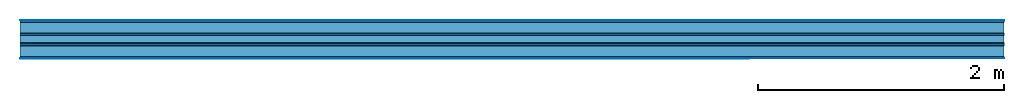
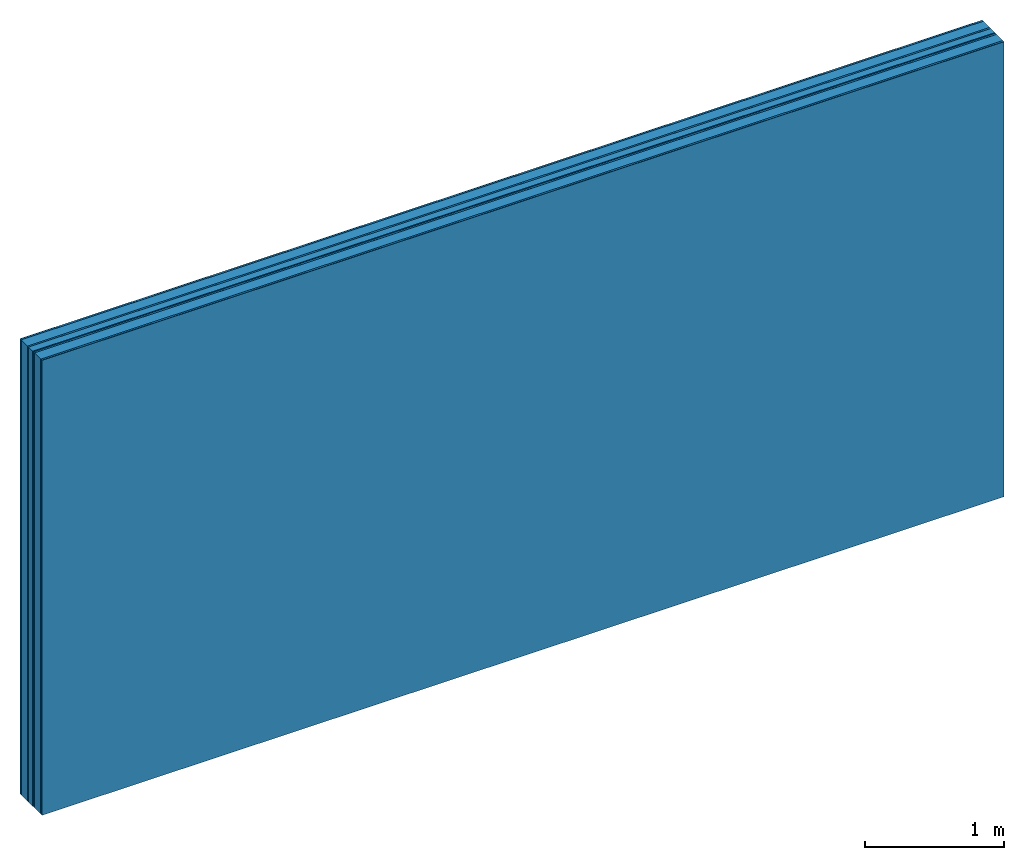
# One storey: 8 plates, 2 members, 1 element without a shape of its own.
"""IFC4 building model written with IfcOpenShell, lengths in metres."""

import ifcopenshell
import ifcopenshell.guid

model = None  # the IFC model being written
_history = None  # IfcOwnerHistory: only IFC2X3 demands one
_inside = {}  # id of a spatial element -> (the spatial element, [elements in it])
_under = {}  # id of a project, library or spatial element -> (it, [spatial elements below it])
_declared = {}  # id of a project -> (the project, [libraries it declares])
_typed = {}  # id of a type object -> (the type object, [elements of that type])
_made_of = {}  # id of a material, layer set ... -> (it, [elements and type objects made of it])


def new_model(schema):
    """Start an empty IFC model of exactly this schema.

    Asked for "IFC4X3", IfcOpenShell would pick the latest addendum, in which some entities
    have other attributes; the version numbers below select the first issue.
    IFC2X3 requires an IfcOwnerHistory on every rooted entity: one is made here for all.
    """
    global model, _history
    if schema == "IFC4X3":
        model = ifcopenshell.file(schema_version=(4, 3, 0, 0))
    else:
        model = ifcopenshell.file(schema=schema)
    _inside.clear()
    _under.clear()
    _declared.clear()
    _typed.clear()
    _made_of.clear()
    _history = None
    if model.schema == "IFC2X3":
        org = make("IfcOrganization", Name="unknown")
        user = make(
            "IfcPersonAndOrganization",
            ThePerson=make("IfcPerson", FamilyName="unknown"),
            TheOrganization=org,
        )
        app = make(
            "IfcApplication",
            ApplicationDeveloper=org,
            Version="unknown",
            ApplicationFullName="unknown",
            ApplicationIdentifier="unknown",
        )
        _history = make(
            "IfcOwnerHistory",
            OwningUser=user,
            OwningApplication=app,
            ChangeAction="ADDED",
            CreationDate=0,
        )
    return model


def make(cls, **values):
    """One entity of the class cls with the attributes given. An attribute that is None is left unset."""
    return model.create_entity(
        cls, **{name: value for name, value in values.items() if value is not None}
    )


def rooted(cls, **values):
    """An entity with a GlobalId (a new one), such as an element, a storey or a relation."""
    return make(cls, GlobalId=ifcopenshell.guid.new(), OwnerHistory=_history, **values)


def si_unit(unit_type, name, prefix=None):
    """IfcSIUnit, for example si_unit("LENGTHUNIT", "METRE", prefix="MILLI")."""
    return make("IfcSIUnit", UnitType=unit_type, Prefix=prefix, Name=name)


def derived_unit(unit_type, elements):
    """IfcDerivedUnit: a product of units, each with its exponent."""
    return make(
        "IfcDerivedUnit",
        Elements=[
            make("IfcDerivedUnitElement", Unit=unit, Exponent=power)
            for unit, power in elements
        ],
        UnitType=unit_type,
    )


def assignment(units):
    """IfcUnitAssignment: the units of a project."""
    return None if units is None else make("IfcUnitAssignment", Units=units)


def point(xyz):
    """IfcCartesianPoint."""
    return None if xyz is None else make("IfcCartesianPoint", Coordinates=xyz)


def direction(xyz):
    """IfcDirection."""
    return None if xyz is None else make("IfcDirection", DirectionRatios=xyz)


def frame(location, z_axis=None, x_axis=None):
    """IfcAxis2Placement3D, a coordinate frame: its origin and axes. An axis left out is left unset."""
    return make(
        "IfcAxis2Placement3D",
        Location=point(location),
        Axis=direction(z_axis),
        RefDirection=direction(x_axis),
    )


def frame_2d(location, x_axis=None):
    """IfcAxis2Placement2D, a coordinate frame in the plane: its origin and x axis."""
    return make(
        "IfcAxis2Placement2D", Location=point(location), RefDirection=direction(x_axis)
    )


def origin():
    """The frame at (0, 0, 0) with its axes left unset."""
    return frame((0.0, 0.0, 0.0))


def origin_with_axes():
    """The frame at (0, 0, 0) with the z axis (0, 0, 1) and the x axis (1, 0, 0) written out."""
    return frame((0.0, 0.0, 0.0), z_axis=(0.0, 0.0, 1.0), x_axis=(1.0, 0.0, 0.0))


def place(relative_to, where):
    """IfcLocalPlacement: puts the frame where relative to a parent placement (None: the world)."""
    return make(
        "IfcLocalPlacement", PlacementRelTo=relative_to, RelativePlacement=where
    )


def context(
    kind, dimensions, precision=None, world=None, true_north=None, identifier=None
):
    """IfcGeometricRepresentationContext, for example the 3D "Model" context."""
    return make(
        "IfcGeometricRepresentationContext",
        ContextIdentifier=identifier,
        ContextType=kind,
        CoordinateSpaceDimension=dimensions,
        Precision=precision,
        WorldCoordinateSystem=world,
        TrueNorth=true_north,
    )


def project(units=None, contexts=None):
    """IfcProject with its units and contexts."""
    return rooted(
        "IfcProject",
        Name="project",
        RepresentationContexts=contexts,
        UnitsInContext=assignment(units),
    )


def spatial(cls, under=None, at=None, **own):
    """A site, building, storey or space (cls), placed at a placement, below another one or the project."""
    s = rooted(cls, ObjectPlacement=at, **own)
    if under is not None:
        _under.setdefault(under.id(), (under, []))[1].append(s)
    return s


def profile(cls, at=None, kind="AREA", **sizes):
    """A parametric profile (cls). Its sizes go by their IFC names, for example OverallWidth=200.0."""
    return make(cls, ProfileType=kind, Position=at, **sizes)


def rectangle(**sizes):
    """IfcRectangleProfileDef."""
    return profile("IfcRectangleProfileDef", **sizes)


def extrude(swept, where, along, depth):
    """IfcExtrudedAreaSolid: the profile swept, set in the frame where, extruded along a direction by depth."""
    return make(
        "IfcExtrudedAreaSolid",
        SweptArea=swept,
        Position=where,
        ExtrudedDirection=direction(along),
        Depth=depth,
    )


def shape(context_of_items, identifier, shape_type, items):
    """IfcShapeRepresentation: the items that make up one representation, for example the "Body"."""
    return make(
        "IfcShapeRepresentation",
        ContextOfItems=context_of_items,
        RepresentationIdentifier=identifier,
        RepresentationType=shape_type,
        Items=items,
    )


def material(Name=None, Category=None):
    """IfcMaterial."""
    return make("IfcMaterial", Name=Name, Category=Category)


def layer(
    of_material, thickness, ventilated=None, Name=None, Category=None, Priority=None
):
    """IfcMaterialLayer: one layer of a wall or slab, of a material (None: an air gap)."""
    return make(
        "IfcMaterialLayer",
        Material=of_material,
        LayerThickness=thickness,
        IsVentilated=ventilated,
        Name=Name,
        Category=Category,
        Priority=Priority,
    )


def layer_set(layers, Name=None):
    """IfcMaterialLayerSet."""
    return make("IfcMaterialLayerSet", MaterialLayers=layers, LayerSetName=Name)


def made_of(thing, what):
    """Note that an element or type object is made of a material, layer set ...; save() writes the relation."""
    if what is not None:
        _made_of.setdefault(what.id(), (what, []))[1].append(thing)
    return thing


def type_object(cls, material=None, **own):
    """A type object (cls), such as IfcWallType, which elements share."""
    return made_of(rooted(cls, **own), material)


def element(
    cls,
    number,
    at=None,
    inside=None,
    cuts=None,
    type_object=None,
    material=None,
    context=None,
    identifier="Body",
    shape_type=None,
    held_by="IfcProductDefinitionShape",
    body=None,
    shapes=None,
    **own,
):
    """One element of the class cls, such as IfcWall. Its Tag is "e" and its number.

    at: its placement. inside: the storey or other place that contains it. cuts: it is an
    opening in that element (IfcRelVoidsElement). A single representation is given by context,
    identifier, shape_type and body (its items); several are given by shapes. held_by: the class
    of the entity that holds the representations. save() writes the other relations.
    """
    e = rooted(cls, Tag="e%d" % number, ObjectPlacement=at, **own)
    if body is not None:
        shapes = [shape(context, identifier, shape_type, body)]
    if shapes is not None:
        e.Representation = make(held_by, Representations=shapes)
    if inside is not None:
        _inside.setdefault(inside.id(), (inside, []))[1].append(e)
    if cuts is not None:
        rooted(
            "IfcRelVoidsElement", RelatingBuildingElement=cuts, RelatedOpeningElement=e
        )
    if type_object is not None:
        _typed.setdefault(type_object.id(), (type_object, []))[1].append(e)
    return made_of(e, material)


def aggregate(whole, parts):
    """IfcRelAggregates: a whole, such as a stair, and the parts it consists of."""
    return rooted("IfcRelAggregates", RelatingObject=whole, RelatedObjects=parts)


def save(model, path):
    """Write the relations noted so far, then the file.

    IfcRelAggregates (storeys below a building ...), IfcRelContainedInSpatialStructure (elements
    in a storey), IfcRelDefinesByType, IfcRelAssociatesMaterial and IfcRelDeclares: one each for
    every whole, place, type object, material and project.
    """
    for whole, parts in _under.values():
        aggregate(whole, parts)
    for where, things in _inside.values():
        rooted(
            "IfcRelContainedInSpatialStructure",
            RelatedElements=things,
            RelatingStructure=where,
        )
    for kind, things in _typed.values():
        rooted("IfcRelDefinesByType", RelatedObjects=things, RelatingType=kind)
    for what, things in _made_of.values():
        rooted("IfcRelAssociatesMaterial", RelatedObjects=things, RelatingMaterial=what)
    for by, libraries in _declared.values():
        rooted("IfcRelDeclares", RelatingContext=by, RelatedDefinitions=libraries)
    model.write(path)


model = new_model("IFC4")

# Units and contexts
plan_context = context("Plan", 3, precision=1e-05, world=origin(), true_north=direction((0.0, 1.0)))
model_context = context("Model", 3, precision=1e-05, world=origin(), true_north=direction((0.0, 1.0)))
ifc_project = project(units=[si_unit("LENGTHUNIT", "METRE"), derived_unit("SOUNDPRESSUREUNIT", [(si_unit("PRESSUREUNIT", "PASCAL", prefix="MICRO"), 0)]), si_unit("ENERGYUNIT", "JOULE", prefix="MEGA"), si_unit("MASSUNIT", "GRAM", prefix="KILO"), derived_unit("THERMALTRANSMITTANCEUNIT", [(si_unit("POWERUNIT", "WATT"), 1), (si_unit("AREAUNIT", "SQUARE_METRE"), -1), (si_unit("THERMODYNAMICTEMPERATUREUNIT", "KELVIN"), -1)]), derived_unit("AREADENSITYUNIT", [(si_unit("MASSUNIT", "GRAM", prefix="KILO"), 1), (si_unit("AREAUNIT", "SQUARE_METRE"), -1)]), derived_unit("USERDEFINED", [(si_unit("ENERGYUNIT", "JOULE", prefix="MEGA"), 1), (si_unit("AREAUNIT", "SQUARE_METRE"), -1)])], contexts=[plan_context, model_context])

# Site, building, storey
site = spatial("IfcSite", under=ifc_project)
building_placement = place(None, origin())
building = spatial("IfcBuilding", under=site, at=building_placement)
storey_placement = place(building_placement, origin())
storey = spatial("IfcBuildingStorey", under=building, at=storey_placement)

# Wall, members, plates
ifc_material_1 = material(Category="04.001")
ifc_layer_1 = layer(ifc_material_1, 0.003, Name="Surface")
ifc_material_2 = material(Name="DFH2IR Knauf Diamant hard- plasterboard", Category="03.007")
ifc_layer_2 = layer(ifc_material_2, 0.015, Name="room side 1st layer")
ifc_material_3 = material(Name="of the art")
ifc_layer_3 = layer(ifc_material_3, 0.0, Name="Bond")
ifc_layer_4 = layer(None, 0.09, Name="Support")
ifc_layer_5 = layer(ifc_material_3, 0.0, Name="Bond")
ifc_layer_6 = layer(ifc_material_2, 0.015, Name="outside 1st layer")
ifc_material_4 = material(Category="10.008")
ifc_layer_7 = layer(ifc_material_4, 0.06, Name="Intermediate insulation")
ifc_material_5 = material(Name="Air")
ifc_layer_8 = layer(ifc_material_5, 0.01, Name="Air gap")
ifc_layer_9 = layer(ifc_material_2, 0.015, Name="outside 1st layer")
ifc_layer_10 = layer(ifc_material_3, 0.0, Name="Bond")
ifc_layer_11 = layer(None, 0.09, Name="Support")
ifc_layer_12 = layer(ifc_material_3, 0.0, Name="Bond")
ifc_layer_13 = layer(ifc_material_2, 0.015, Name="room side 1st layer")
ifc_layer_14 = layer(ifc_material_1, 0.003, Name="Surface")
ifc_layer_set = layer_set([ifc_layer_1, ifc_layer_2, ifc_layer_3, ifc_layer_4, ifc_layer_5, ifc_layer_6, ifc_layer_7, ifc_layer_8, ifc_layer_9, ifc_layer_10, ifc_layer_11, ifc_layer_12, ifc_layer_13, ifc_layer_14])
wall_type = type_object("IfcWallType", Name="B0300", PredefinedType="NOTDEFINED", material=ifc_layer_set)
wall_placement = place(None, frame((0.0, 0.0, 0.0), z_axis=(0.0, -1.0, 0.0), x_axis=(1.0, 0.0, 0.0)))
wall = element("IfcWall", 1, at=wall_placement, inside=storey, type_object=wall_type, material=ifc_layer_set, Name="Wall #1")
ifc_material_6 = material(Name="Solid timber panel")
member_1_placement = place(wall_placement, origin())
member_1 = element("IfcMember", 2, at=member_1_placement, material=ifc_material_6, Name="Support", context=plan_context, shape_type="SweptSolid", body=[
    extrude(rectangle(XDim=1.0, YDim=0.09, at=frame_2d((0.5, 0.045), x_axis=(1.0, 0.0))), frame((0.0, 4.0, 0.018), z_axis=(0.0, -1.0, 0.0), x_axis=(1.0, 0.0, 0.0)), (0.0, 0.0, 1.0), 4.0),
    extrude(rectangle(XDim=1.0, YDim=0.09, at=frame_2d((0.5, 0.045), x_axis=(1.0, 0.0))), frame((1.0, 4.0, 0.018), z_axis=(0.0, -1.0, 0.0), x_axis=(1.0, 0.0, 0.0)), (0.0, 0.0, 1.0), 4.0),
    extrude(rectangle(XDim=1.0, YDim=0.09, at=frame_2d((0.5, 0.045), x_axis=(1.0, 0.0))), frame((2.0, 4.0, 0.018), z_axis=(0.0, -1.0, 0.0), x_axis=(1.0, 0.0, 0.0)), (0.0, 0.0, 1.0), 4.0),
    extrude(rectangle(XDim=1.0, YDim=0.09, at=frame_2d((0.5, 0.045), x_axis=(1.0, 0.0))), frame((3.0, 4.0, 0.018), z_axis=(0.0, -1.0, 0.0), x_axis=(1.0, 0.0, 0.0)), (0.0, 0.0, 1.0), 4.0),
    extrude(rectangle(XDim=1.0, YDim=0.09, at=frame_2d((0.5, 0.045), x_axis=(1.0, 0.0))), frame((4.0, 4.0, 0.018), z_axis=(0.0, -1.0, 0.0), x_axis=(1.0, 0.0, 0.0)), (0.0, 0.0, 1.0), 4.0),
    extrude(rectangle(XDim=1.0, YDim=0.09, at=frame_2d((0.5, 0.045), x_axis=(1.0, 0.0))), frame((5.0, 4.0, 0.018), z_axis=(0.0, -1.0, 0.0), x_axis=(1.0, 0.0, 0.0)), (0.0, 0.0, 1.0), 4.0),
    extrude(rectangle(XDim=1.0, YDim=0.09, at=frame_2d((0.5, 0.045), x_axis=(1.0, 0.0))), frame((6.0, 4.0, 0.018), z_axis=(0.0, -1.0, 0.0), x_axis=(1.0, 0.0, 0.0)), (0.0, 0.0, 1.0), 4.0),
    extrude(rectangle(XDim=1.0, YDim=0.09, at=frame_2d((0.5, 0.045), x_axis=(1.0, 0.0))), frame((7.0, 4.0, 0.018), z_axis=(0.0, -1.0, 0.0), x_axis=(1.0, 0.0, 0.0)), (0.0, 0.0, 1.0), 4.0),
])
member_2_placement = place(wall_placement, origin())
member_2 = element("IfcMember", 3, at=member_2_placement, material=ifc_material_6, Name="Support", context=plan_context, shape_type="SweptSolid", body=[
    extrude(rectangle(XDim=1.0, YDim=0.09, at=frame_2d((0.5, 0.045), x_axis=(1.0, 0.0))), frame((0.0, 4.0, 0.208), z_axis=(0.0, -1.0, 0.0), x_axis=(1.0, 0.0, 0.0)), (0.0, 0.0, 1.0), 4.0),
    extrude(rectangle(XDim=1.0, YDim=0.09, at=frame_2d((0.5, 0.045), x_axis=(1.0, 0.0))), frame((1.0, 4.0, 0.208), z_axis=(0.0, -1.0, 0.0), x_axis=(1.0, 0.0, 0.0)), (0.0, 0.0, 1.0), 4.0),
    extrude(rectangle(XDim=1.0, YDim=0.09, at=frame_2d((0.5, 0.045), x_axis=(1.0, 0.0))), frame((2.0, 4.0, 0.208), z_axis=(0.0, -1.0, 0.0), x_axis=(1.0, 0.0, 0.0)), (0.0, 0.0, 1.0), 4.0),
    extrude(rectangle(XDim=1.0, YDim=0.09, at=frame_2d((0.5, 0.045), x_axis=(1.0, 0.0))), frame((3.0, 4.0, 0.208), z_axis=(0.0, -1.0, 0.0), x_axis=(1.0, 0.0, 0.0)), (0.0, 0.0, 1.0), 4.0),
    extrude(rectangle(XDim=1.0, YDim=0.09, at=frame_2d((0.5, 0.045), x_axis=(1.0, 0.0))), frame((4.0, 4.0, 0.208), z_axis=(0.0, -1.0, 0.0), x_axis=(1.0, 0.0, 0.0)), (0.0, 0.0, 1.0), 4.0),
    extrude(rectangle(XDim=1.0, YDim=0.09, at=frame_2d((0.5, 0.045), x_axis=(1.0, 0.0))), frame((5.0, 4.0, 0.208), z_axis=(0.0, -1.0, 0.0), x_axis=(1.0, 0.0, 0.0)), (0.0, 0.0, 1.0), 4.0),
    extrude(rectangle(XDim=1.0, YDim=0.09, at=frame_2d((0.5, 0.045), x_axis=(1.0, 0.0))), frame((6.0, 4.0, 0.208), z_axis=(0.0, -1.0, 0.0), x_axis=(1.0, 0.0, 0.0)), (0.0, 0.0, 1.0), 4.0),
    extrude(rectangle(XDim=1.0, YDim=0.09, at=frame_2d((0.5, 0.045), x_axis=(1.0, 0.0))), frame((7.0, 4.0, 0.208), z_axis=(0.0, -1.0, 0.0), x_axis=(1.0, 0.0, 0.0)), (0.0, 0.0, 1.0), 4.0),
])
plate_1_placement = place(wall_placement, origin())
plate_1 = element("IfcPlate", 4, at=plate_1_placement, material=ifc_material_1, Name="Surface", context=plan_context, shape_type="SweptSolid", body=[
    extrude(rectangle(XDim=8.0, YDim=4.0, at=frame_2d((4.0, 2.0), x_axis=(1.0, 0.0))), origin_with_axes(), (0.0, 0.0, 1.0), 0.003),
])
plate_2_placement = place(wall_placement, origin())
plate_2 = element("IfcPlate", 5, at=plate_2_placement, material=ifc_material_2, Name="room side 1st layer", context=plan_context, shape_type="SweptSolid", body=[
    extrude(rectangle(XDim=8.0, YDim=4.0, at=frame_2d((4.0, 2.0), x_axis=(1.0, 0.0))), frame((0.0, 0.0, 0.003), z_axis=(0.0, 0.0, 1.0), x_axis=(1.0, 0.0, 0.0)), (0.0, 0.0, 1.0), 0.015),
])
plate_3_placement = place(wall_placement, origin())
plate_3 = element("IfcPlate", 6, at=plate_3_placement, material=ifc_material_2, Name="outside 1st layer", context=plan_context, shape_type="SweptSolid", body=[
    extrude(rectangle(XDim=8.0, YDim=4.0, at=frame_2d((4.0, 2.0), x_axis=(1.0, 0.0))), frame((0.0, 0.0, 0.108), z_axis=(0.0, 0.0, 1.0), x_axis=(1.0, 0.0, 0.0)), (0.0, 0.0, 1.0), 0.015),
])
plate_4_placement = place(wall_placement, origin())
plate_4 = element("IfcPlate", 7, at=plate_4_placement, material=ifc_material_4, Name="Intermediate insulation", context=plan_context, shape_type="SweptSolid", body=[
    extrude(rectangle(XDim=8.0, YDim=4.0, at=frame_2d((4.0, 2.0), x_axis=(1.0, 0.0))), frame((0.0, 0.0, 0.123), z_axis=(0.0, 0.0, 1.0), x_axis=(1.0, 0.0, 0.0)), (0.0, 0.0, 1.0), 0.06),
])
plate_5_placement = place(wall_placement, origin())
plate_5 = element("IfcPlate", 8, at=plate_5_placement, material=ifc_material_5, Name="Air gap", context=plan_context, shape_type="SweptSolid", body=[
    extrude(rectangle(XDim=8.0, YDim=4.0, at=frame_2d((4.0, 2.0), x_axis=(1.0, 0.0))), frame((0.0, 0.0, 0.183), z_axis=(0.0, 0.0, 1.0), x_axis=(1.0, 0.0, 0.0)), (0.0, 0.0, 1.0), 0.01),
])
plate_6_placement = place(wall_placement, origin())
plate_6 = element("IfcPlate", 9, at=plate_6_placement, material=ifc_material_2, Name="outside 1st layer", context=plan_context, shape_type="SweptSolid", body=[
    extrude(rectangle(XDim=8.0, YDim=4.0, at=frame_2d((4.0, 2.0), x_axis=(1.0, 0.0))), frame((0.0, 0.0, 0.193), z_axis=(0.0, 0.0, 1.0), x_axis=(1.0, 0.0, 0.0)), (0.0, 0.0, 1.0), 0.015),
])
plate_7_placement = place(wall_placement, origin())
plate_7 = element("IfcPlate", 10, at=plate_7_placement, material=ifc_material_2, Name="room side 1st layer", context=plan_context, shape_type="SweptSolid", body=[
    extrude(rectangle(XDim=8.0, YDim=4.0, at=frame_2d((4.0, 2.0), x_axis=(1.0, 0.0))), frame((0.0, 0.0, 0.298), z_axis=(0.0, 0.0, 1.0), x_axis=(1.0, 0.0, 0.0)), (0.0, 0.0, 1.0), 0.015),
])
plate_8_placement = place(wall_placement, origin())
plate_8 = element("IfcPlate", 11, at=plate_8_placement, material=ifc_material_1, Name="Surface", context=plan_context, shape_type="SweptSolid", body=[
    extrude(rectangle(XDim=8.0, YDim=4.0, at=frame_2d((4.0, 2.0), x_axis=(1.0, 0.0))), frame((0.0, 0.0, 0.313), z_axis=(0.0, 0.0, 1.0), x_axis=(1.0, 0.0, 0.0)), (0.0, 0.0, 1.0), 0.003),
])
aggregate(wall, [plate_1, plate_2, member_1, plate_3, plate_4, plate_5, plate_6, member_2, plate_7, plate_8])

save(model, "model.ifc")
